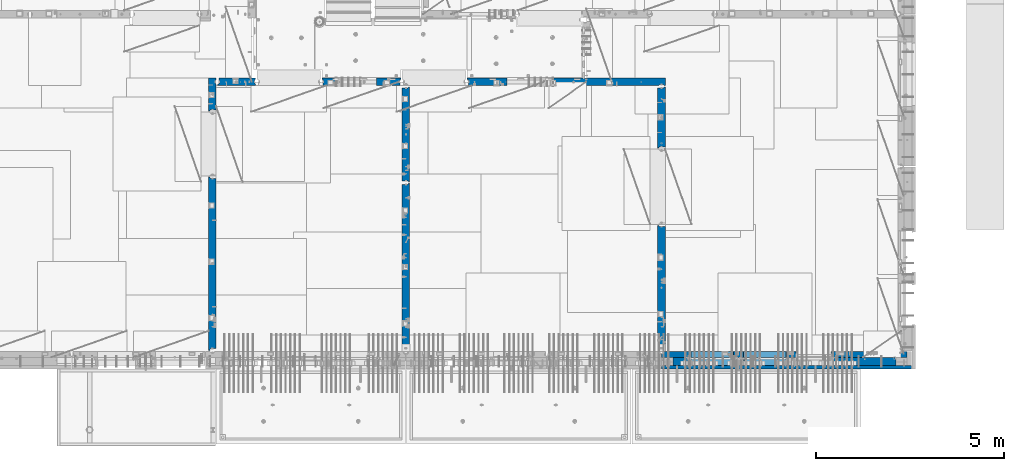
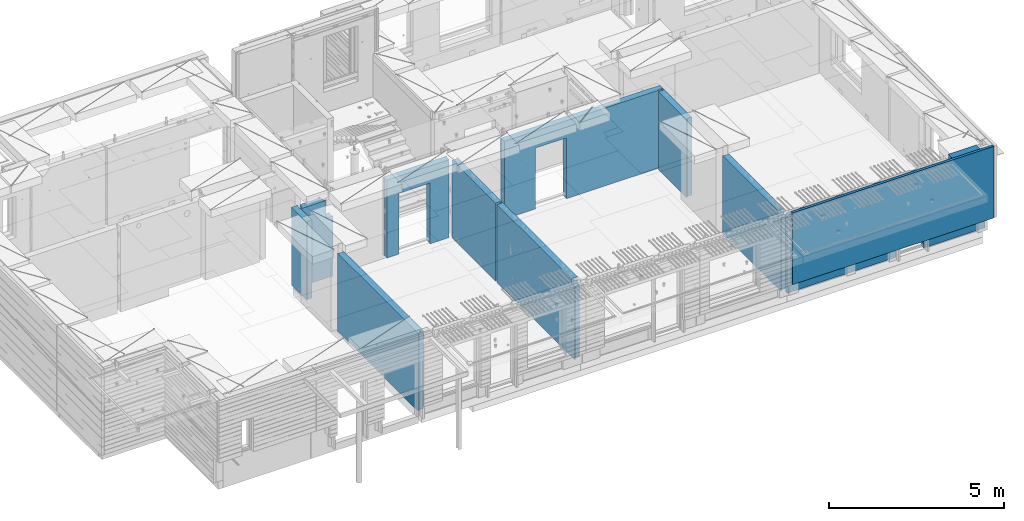
# One storey, part 213 of 325: 12 walls, 10 elements without a shape of their own.
"""IFC2X3 building model written with IfcOpenShell, lengths in millimetres."""

import ifcopenshell
import ifcopenshell.guid

model = None  # the IFC model being written
_history = None  # IfcOwnerHistory: only IFC2X3 demands one
_inside = {}  # id of a spatial element -> (the spatial element, [elements in it])
_under = {}  # id of a project, library or spatial element -> (it, [spatial elements below it])
_declared = {}  # id of a project -> (the project, [libraries it declares])
_typed = {}  # id of a type object -> (the type object, [elements of that type])
_made_of = {}  # id of a material, layer set ... -> (it, [elements and type objects made of it])


def new_model(schema):
    """Start an empty IFC model of exactly this schema.

    Asked for "IFC4X3", IfcOpenShell would pick the latest addendum, in which some entities
    have other attributes; the version numbers below select the first issue.
    IFC2X3 requires an IfcOwnerHistory on every rooted entity: one is made here for all.
    """
    global model, _history
    if schema == "IFC4X3":
        model = ifcopenshell.file(schema_version=(4, 3, 0, 0))
    else:
        model = ifcopenshell.file(schema=schema)
    _inside.clear()
    _under.clear()
    _declared.clear()
    _typed.clear()
    _made_of.clear()
    _history = None
    if model.schema == "IFC2X3":
        org = make("IfcOrganization", Name="unknown")
        user = make(
            "IfcPersonAndOrganization",
            ThePerson=make("IfcPerson", FamilyName="unknown"),
            TheOrganization=org,
        )
        app = make(
            "IfcApplication",
            ApplicationDeveloper=org,
            Version="unknown",
            ApplicationFullName="unknown",
            ApplicationIdentifier="unknown",
        )
        _history = make(
            "IfcOwnerHistory",
            OwningUser=user,
            OwningApplication=app,
            ChangeAction="ADDED",
            CreationDate=0,
        )
    return model


def make(cls, **values):
    """One entity of the class cls with the attributes given. An attribute that is None is left unset."""
    return model.create_entity(
        cls, **{name: value for name, value in values.items() if value is not None}
    )


def rooted(cls, **values):
    """An entity with a GlobalId (a new one), such as an element, a storey or a relation."""
    return make(cls, GlobalId=ifcopenshell.guid.new(), OwnerHistory=_history, **values)


def si_unit(unit_type, name, prefix=None):
    """IfcSIUnit, for example si_unit("LENGTHUNIT", "METRE", prefix="MILLI")."""
    return make("IfcSIUnit", UnitType=unit_type, Prefix=prefix, Name=name)


def assignment(units):
    """IfcUnitAssignment: the units of a project."""
    return None if units is None else make("IfcUnitAssignment", Units=units)


def point(xyz):
    """IfcCartesianPoint."""
    return None if xyz is None else make("IfcCartesianPoint", Coordinates=xyz)


def direction(xyz):
    """IfcDirection."""
    return None if xyz is None else make("IfcDirection", DirectionRatios=xyz)


def frame(location, z_axis=None, x_axis=None):
    """IfcAxis2Placement3D, a coordinate frame: its origin and axes. An axis left out is left unset."""
    return make(
        "IfcAxis2Placement3D",
        Location=point(location),
        Axis=direction(z_axis),
        RefDirection=direction(x_axis),
    )


def origin_with_axes():
    """The frame at (0, 0, 0) with the z axis (0, 0, 1) and the x axis (1, 0, 0) written out."""
    return frame((0.0, 0.0, 0.0), z_axis=(0.0, 0.0, 1.0), x_axis=(1.0, 0.0, 0.0))


def place(relative_to, where):
    """IfcLocalPlacement: puts the frame where relative to a parent placement (None: the world)."""
    return make(
        "IfcLocalPlacement", PlacementRelTo=relative_to, RelativePlacement=where
    )


def context(
    kind, dimensions, precision=None, world=None, true_north=None, identifier=None
):
    """IfcGeometricRepresentationContext, for example the 3D "Model" context."""
    return make(
        "IfcGeometricRepresentationContext",
        ContextIdentifier=identifier,
        ContextType=kind,
        CoordinateSpaceDimension=dimensions,
        Precision=precision,
        WorldCoordinateSystem=world,
        TrueNorth=true_north,
    )


def subcontext(parent, identifier, kind, view, scale=None):
    """IfcGeometricRepresentationSubContext, for example "Body" below "Model"."""
    return make(
        "IfcGeometricRepresentationSubContext",
        ContextIdentifier=identifier,
        ContextType=kind,
        ParentContext=parent,
        TargetScale=scale,
        TargetView=view,
    )


def project(units=None, contexts=None):
    """IfcProject with its units and contexts."""
    return rooted(
        "IfcProject",
        Name="project",
        RepresentationContexts=contexts,
        UnitsInContext=assignment(units),
    )


def spatial(cls, under=None, at=None, **own):
    """A site, building, storey or space (cls), placed at a placement, below another one or the project."""
    s = rooted(cls, ObjectPlacement=at, **own)
    if under is not None:
        _under.setdefault(under.id(), (under, []))[1].append(s)
    return s


def faces_of(points, faces, orient=None, outer=None):
    """IfcFace entities. A face is a list of loops; a loop is a list of indices into points, from 0.

    orient and outer hold one flag for each loop. By default every Orientation is true, the
    first loop of a face is its IfcFaceOuterBound and the others are IfcFaceBound.
    """
    made = []
    for i, loops in enumerate(faces):
        bounds = []
        for j, loop in enumerate(loops):
            is_outer = j == 0 if outer is None else outer[i][j]
            bounds.append(
                make(
                    "IfcFaceOuterBound" if is_outer else "IfcFaceBound",
                    Bound=make("IfcPolyLoop", Polygon=[points[k] for k in loop]),
                    Orientation=True if orient is None else orient[i][j],
                )
            )
        made.append(make("IfcFace", Bounds=bounds))
    return made


def faceted_brep(points, faces, orient=None, outer=None, voids=None):
    """IfcFacetedBrep: a solid bounded by flat faces; with voids (closed shells), ...WithVoids."""
    shared = [point(p) for p in points]
    hull = make("IfcClosedShell", CfsFaces=faces_of(shared, faces, orient, outer))
    if voids is None:
        return make("IfcFacetedBrep", Outer=hull)
    return make(
        "IfcFacetedBrepWithVoids",
        Outer=hull,
        Voids=[
            make(cls, CfsFaces=faces_of(shared, fs, o, b)) for cls, fs, o, b in voids
        ],
    )


def shape(context_of_items, identifier, shape_type, items):
    """IfcShapeRepresentation: the items that make up one representation, for example the "Body"."""
    return make(
        "IfcShapeRepresentation",
        ContextOfItems=context_of_items,
        RepresentationIdentifier=identifier,
        RepresentationType=shape_type,
        Items=items,
    )


def material(Name=None, Category=None):
    """IfcMaterial."""
    return make("IfcMaterial", Name=Name, Category=Category)


def made_of(thing, what):
    """Note that an element or type object is made of a material, layer set ...; save() writes the relation."""
    if what is not None:
        _made_of.setdefault(what.id(), (what, []))[1].append(thing)
    return thing


def type_object(cls, material=None, **own):
    """A type object (cls), such as IfcWallType, which elements share."""
    return made_of(rooted(cls, **own), material)


def element(
    cls,
    number,
    at=None,
    inside=None,
    cuts=None,
    type_object=None,
    material=None,
    context=None,
    identifier="Body",
    shape_type=None,
    held_by="IfcProductDefinitionShape",
    body=None,
    shapes=None,
    **own,
):
    """One element of the class cls, such as IfcWall. Its Tag is "e" and its number.

    at: its placement. inside: the storey or other place that contains it. cuts: it is an
    opening in that element (IfcRelVoidsElement). A single representation is given by context,
    identifier, shape_type and body (its items); several are given by shapes. held_by: the class
    of the entity that holds the representations. save() writes the other relations.
    """
    e = rooted(cls, Tag="e%d" % number, ObjectPlacement=at, **own)
    if body is not None:
        shapes = [shape(context, identifier, shape_type, body)]
    if shapes is not None:
        e.Representation = make(held_by, Representations=shapes)
    if inside is not None:
        _inside.setdefault(inside.id(), (inside, []))[1].append(e)
    if cuts is not None:
        rooted(
            "IfcRelVoidsElement", RelatingBuildingElement=cuts, RelatedOpeningElement=e
        )
    if type_object is not None:
        _typed.setdefault(type_object.id(), (type_object, []))[1].append(e)
    return made_of(e, material)


def aggregate(whole, parts):
    """IfcRelAggregates: a whole, such as a stair, and the parts it consists of."""
    return rooted("IfcRelAggregates", RelatingObject=whole, RelatedObjects=parts)


def save(model, path):
    """Write the relations noted so far, then the file.

    IfcRelAggregates (storeys below a building ...), IfcRelContainedInSpatialStructure (elements
    in a storey), IfcRelDefinesByType, IfcRelAssociatesMaterial and IfcRelDeclares: one each for
    every whole, place, type object, material and project.
    """
    for whole, parts in _under.values():
        aggregate(whole, parts)
    for where, things in _inside.values():
        rooted(
            "IfcRelContainedInSpatialStructure",
            RelatedElements=things,
            RelatingStructure=where,
        )
    for kind, things in _typed.values():
        rooted("IfcRelDefinesByType", RelatedObjects=things, RelatingType=kind)
    for what, things in _made_of.values():
        rooted("IfcRelAssociatesMaterial", RelatedObjects=things, RelatingMaterial=what)
    for by, libraries in _declared.values():
        rooted("IfcRelDeclares", RelatingContext=by, RelatedDefinitions=libraries)
    model.write(path)


model = new_model("IFC2X3")

# Units and contexts
model_context = context("Model", 3, precision=1e-05, world=origin_with_axes())
body_context = subcontext(model_context, "Body", "Model", "MODEL_VIEW")
ifc_project = project(units=[si_unit("LENGTHUNIT", "METRE", prefix="MILLI"), si_unit("AREAUNIT", "SQUARE_METRE"), si_unit("VOLUMEUNIT", "CUBIC_METRE"), si_unit("MASSUNIT", "GRAM", prefix="KILO"), si_unit("TIMEUNIT", "SECOND"), si_unit("PLANEANGLEUNIT", "RADIAN"), si_unit("SOLIDANGLEUNIT", "STERADIAN"), si_unit("THERMODYNAMICTEMPERATUREUNIT", "DEGREE_CELSIUS"), si_unit("LUMINOUSINTENSITYUNIT", "LUMEN")], contexts=[model_context])

# Site, building, storey
site_placement = place(None, origin_with_axes())
site = spatial("IfcSite", under=ifc_project, at=site_placement, CompositionType="ELEMENT")
building_placement = place(site_placement, origin_with_axes())
building = spatial("IfcBuilding", under=site, at=building_placement, CompositionType="ELEMENT")
storey_placement = place(building_placement, origin_with_axes())
storey = spatial("IfcBuildingStorey", under=building, at=storey_placement, Name="1", CompositionType="ELEMENT", Elevation=0.0)

# Assembly, wall
assembly_1_placement = place(storey_placement, origin_with_axes())
assembly_1 = element("IfcElementAssembly", 1, at=assembly_1_placement, inside=storey, AssemblyPlace="NOTDEFINED", PredefinedType="REINFORCEMENT_UNIT")
ifc_material_1 = material(Name="CONCRETE/C25/30")
wall_type_1 = type_object("IfcWallType", PredefinedType="NOTDEFINED")
wall_1_placement = place(assembly_1_placement, frame((16790.0, 15180.0, 83112.5), z_axis=(0.0, 0.0, 1.0), x_axis=(1.0, 0.0, 0.0)))
wall_1 = element("IfcWall", 2, at=wall_1_placement, type_object=wall_type_1, material=ifc_material_1, context=body_context, shape_type="Brep", body=[
    faceted_brep([(1020.0, -65.0002298127583, 737.5), (1020.0, -65.0002298127583, -1357.5), (999.999148194889, -52.0002257561027, -1357.5), (999.999148194889, -52.0002257561027, 737.5), (999.999146609105, 52.0000004570338, -1357.5), (999.999146609105, 52.0000004570338, 737.5), (1019.99914550781, 64.9999999999982, 737.5), (1020.0, 64.9999999999982, -1357.5), (740.0, 100.0, 1357.5), (740.0, -57.0, 1357.5), (740.0, -57.0, 737.5), (740.0, 100.0, 737.5), (50.0, 100.0, 1357.5), (50.0, -48.3299999999999, 1357.5), (0.0, -69.996666666666, 1357.5), (0.0, -100.0, 1357.5), (790.0, -100.0, 1357.5), (790.0, -70.0, 1357.5), (50.0, 100.0, -1357.5), (50.0, -48.3299999999999, -1357.5), (0.0, -69.996666666666, -1357.5), (0.0, -100.0, -1357.5), (1020.0, -100.0, -1357.5), (1020.0, -100.0, 737.5), (790.0, -100.0, 737.5), (790.0, -70.0, 737.5), (790.0, 100.0, 737.5), (840.0, -83.0, 737.5), (840.0, 100.0, 737.5), (1020.0, 100.0, -1357.5), (1020.0, 100.0, 737.5)], [[[0, 1, 2, 3]], [[3, 2, 4, 5]], [[6, 5, 4, 7]], [[8, 9, 10, 11]], [[9, 8, 12, 13, 14, 15, 16, 17]], [[12, 18, 19, 13]], [[13, 19, 20, 14]], [[21, 15, 14, 20]], [[16, 15, 21, 22, 23, 24]], [[17, 16, 24, 25]], [[10, 9, 17, 25]], [[26, 11, 10, 25, 27, 28]], [[29, 18, 12, 8, 11, 26, 28, 30]], [[29, 30, 6, 7]], [[2, 1, 22, 21, 20, 19, 18, 29, 7, 4]], [[23, 22, 1, 0]], [[30, 28, 27, 25, 24, 23, 0, 3, 5, 6]]]),
])
aggregate(assembly_1, [wall_1])

assembly_2_placement = place(storey_placement, origin_with_axes())
assembly_2 = element("IfcElementAssembly", 3, at=assembly_2_placement, inside=storey, AssemblyPlace="NOTDEFINED", PredefinedType="REINFORCEMENT_UNIT")
wall_2_placement = place(assembly_2_placement, frame((28610.0, 13387.9996249472, 83112.5), z_axis=(0.0, 0.0, 1.0), x_axis=(0.0, 1.0, 0.0)))
wall_2 = element("IfcWall", 4, at=wall_2_placement, type_object=wall_type_1, material=ifc_material_1, context=body_context, shape_type="Brep", body=[
    faceted_brep([(30.9999999999982, 70.0000000000073, 1357.5), (30.9999999999982, 70.0000000000073, -1357.5), (60.9999999999982, 57.0000000000036, -1357.5), (60.9999999999982, 57.0000000000036, 1357.5), (60.9999999999982, -100.0, 1357.5), (60.9999999999982, -100.0, -1357.5), (30.9999999999982, 100.0, -1357.5), (30.9999999999982, 100.0, 1357.5), (1631.00037505278, 100.0, 1357.5), (1631.00037505278, 100.0, -1357.5), (1631.00037505278, -56.9999999999964, 1357.5), (1631.00037505278, -56.9999999999964, -1357.5), (1661.00037505278, -70.0, 1357.5), (1661.00037505278, -70.0, -1357.5), (1661.00037505278, -100.0, 1357.5), (1661.00037505278, -100.0, -1357.5)], [[[0, 1, 2, 3]], [[4, 3, 2, 5]], [[6, 7, 8, 9]], [[10, 11, 9, 8]], [[12, 13, 11, 10]], [[14, 15, 13, 12]], [[15, 14, 4, 5]], [[1, 6, 9, 11, 13, 15, 5, 2]], [[7, 6, 1, 0]], [[14, 12, 10, 8, 7, 0, 3, 4]]]),
])
aggregate(assembly_2, [wall_2])

assembly_3_placement = place(storey_placement, origin_with_axes())
assembly_3 = element("IfcElementAssembly", 5, at=assembly_3_placement, inside=storey, AssemblyPlace="NOTDEFINED", PredefinedType="REINFORCEMENT_UNIT")
wall_3_placement = place(assembly_3_placement, frame((28610.0, 8000.0, 83112.5), z_axis=(0.0, 0.0, 1.0), x_axis=(0.0, 1.0, 0.0)))
wall_3 = element("IfcWall", 6, at=wall_3_placement, type_object=wall_type_1, material=ifc_material_1, context=body_context, shape_type="Brep", body=[
    faceted_brep([(200.000052014346, -100.0, 1157.50076293945), (200.000052014346, 100.0, 1157.50076293945), (30.0, 100.0, 1157.50076293945), (30.0, 70.0, 1157.50076293945), (80.0, 57.0, 1157.50076293945), (80.0, -100.0, 1157.50076293945), (200.000052014346, -100.0, 1357.50076293945), (200.000052014346, 100.0, 1357.5), (30.0, 70.0, -1357.5), (30.0, 100.0, -1357.5), (3360.0, 100.0, -1357.5), (3360.0, 70.0000000000073, -1357.5), (3330.0, 57.0000000000036, -1357.5), (3330.0, -100.0, -1357.5), (80.0, -100.0, -1357.5), (80.0, 57.0, -1357.5), (3360.0, 100.0, 1357.5), (3360.0, 70.0000000000073, 1357.5), (3330.0, 57.0000000000036, 1357.5), (3330.0, -100.0, 1357.5)], [[[0, 1, 2, 3, 4, 5]], [[6, 7, 1, 0]], [[8, 9, 10, 11, 12, 13, 14, 15]], [[10, 16, 17, 11]], [[18, 12, 11, 17]], [[19, 13, 12, 18]], [[5, 14, 13, 19, 6, 0]], [[15, 14, 5, 4]], [[8, 15, 4, 3]], [[9, 8, 3, 2]], [[16, 10, 9, 2, 1, 7]], [[19, 18, 17, 16, 7, 6]]]),
])
aggregate(assembly_3, [wall_3])

assembly_4_placement = place(storey_placement, origin_with_axes())
assembly_4 = element("IfcElementAssembly", 7, at=assembly_4_placement, inside=storey, AssemblyPlace="NOTDEFINED", PredefinedType="REINFORCEMENT_UNIT")
wall_4_placement = place(assembly_4_placement, frame((23410.0002919986, 15180.0, 83112.5), z_axis=(0.0, 0.0, 1.0), x_axis=(1.0, 0.0, 0.0)))
wall_4 = element("IfcWall", 8, at=wall_4_placement, type_object=wall_type_1, material=ifc_material_1, context=body_context, shape_type="Brep", body=[
    faceted_brep([(3134.99885559082, 100.0, 762.5), (3147.99885559082, 80.0, 762.5), (3251.99885559082, 80.0, 762.5), (3264.99885559082, 100.0, 762.5), (3147.99885559082, 80.0, 1357.5), (3134.99885559082, 100.0, 1357.5), (3251.99885559082, 80.0, 1357.5), (3264.99885559082, 100.0, 1357.5), (5299.99970800144, -100.0, -1357.5), (5299.99970800144, -100.0, 1357.5), (5264.99970800144, -100.0, 1357.5), (5264.99970800144, -100.0, -1357.5), (5251.99970800144, -70.0, 1357.5), (5251.99970800144, -70.0, -1357.5), (5147.99970800144, -70.0, 1357.5), (5147.99970800144, -70.0, -1357.5), (5134.99970800144, -100.0, 1357.5), (5134.99970800144, -100.0, -1357.5), (59.9988535092562, -100.0, 1357.5), (59.9988535092562, -100.0, -1357.5), (1090.00039464695, -100.0, -1357.5), (1090.00039464695, -100.0, 762.5), (2110.00039464695, -100.0, 762.5), (2110.00039464695, -100.0, -1357.5), (59.9988535092562, 57.0, 1357.5), (59.9988535092562, 57.0, -1357.5), (29.9988535092562, 70.0000000000018, 1357.5), (29.9988535092562, 70.0000000000018, -1357.5), (29.9988535092562, 100.0, 1357.5), (29.9988535092562, 100.0, -1357.5), (1090.00039464695, 100.0, -1357.5), (1090.00039464695, 100.0, 762.5), (2110.00039464695, 100.0, 762.5), (2110.00039464695, 100.0, -1357.5), (5299.99970800144, 100.0, -1357.5), (5299.99970800144, 100.0, 1357.5)], [[[0, 1, 2, 3]], [[4, 1, 0, 5]], [[6, 2, 1, 4]], [[7, 3, 2, 6]], [[8, 9, 10, 11]], [[10, 12, 13, 11]], [[14, 15, 13, 12]], [[16, 17, 15, 14]], [[17, 16, 18, 19, 20, 21, 22, 23]], [[24, 25, 19, 18]], [[26, 27, 25, 24]], [[28, 29, 27, 26]], [[19, 25, 27, 29, 30, 20]], [[31, 21, 20, 30]], [[32, 22, 21, 31]], [[33, 23, 22, 32]], [[34, 8, 11, 13, 15, 17, 23, 33]], [[9, 8, 34, 35]], [[4, 5, 28, 26, 24, 18, 16, 14, 12, 10, 9, 35, 7, 6]], [[35, 34, 33, 32, 31, 30, 29, 28, 5, 0, 3, 7]]]),
])
aggregate(assembly_4, [wall_4])

assembly_5_placement = place(storey_placement, origin_with_axes())
assembly_5 = element("IfcElementAssembly", 9, at=assembly_5_placement, inside=storey, AssemblyPlace="NOTDEFINED", PredefinedType="REINFORCEMENT_UNIT")
wall_5_placement = place(assembly_5_placement, frame((21810.0, 12500.0, 83112.5), z_axis=(0.0, 0.0, 1.0), x_axis=(0.0, 1.0, 0.0)))
wall_5 = element("IfcWall", 10, at=wall_5_placement, type_object=wall_type_1, material=ifc_material_1, context=body_context, shape_type="Brep", body=[
    faceted_brep([(2519.9998239177, -57.0, 1357.5), (2519.9998239177, -57.0, -1357.5), (2519.9998239177, 100.0, -1357.5), (2519.9998239177, 100.0, 1357.5), (2549.9998239177, -70.0, 1357.5), (2549.9998239177, -70.0, -1357.5), (45.0, 100.0, 1357.5), (45.0, 100.0, -1357.5), (45.0, -57.0, -1357.5), (45.0, -57.0, 1357.5), (15.0, -70.0, 1357.5), (15.0, -70.0000000000036, -1357.5), (15.0, -100.0, -1357.5), (15.0, -100.0, 1357.5), (2549.9998239177, -100.0, -1357.5), (2549.9998239177, -100.0, 1357.5)], [[[0, 1, 2, 3]], [[4, 5, 1, 0]], [[6, 7, 8, 9]], [[10, 9, 8, 11]], [[12, 13, 10, 11]], [[13, 12, 14, 15]], [[3, 6, 9, 10, 13, 15, 4, 0]], [[7, 6, 3, 2]], [[14, 12, 11, 8, 7, 2, 1, 5]], [[15, 14, 5, 4]]]),
])
aggregate(assembly_5, [wall_5])

assembly_6_placement = place(storey_placement, origin_with_axes())
assembly_6 = element("IfcElementAssembly", 11, at=assembly_6_placement, inside=storey, AssemblyPlace="NOTDEFINED", PredefinedType="REINFORCEMENT_UNIT")
wall_6_placement = place(assembly_6_placement, frame((21810.0, 8000.0, 83112.5), z_axis=(0.0, 0.0, 1.0), x_axis=(0.0, 1.0, 0.0)))
wall_6 = element("IfcWall", 12, at=wall_6_placement, type_object=wall_type_1, material=ifc_material_1, context=body_context, shape_type="Brep", body=[
    faceted_brep([(200.000052014346, -100.0, 1157.50076293945), (200.000052014346, 100.0, 1157.50076293945), (30.0, 100.0, 1157.50076293945), (30.0, 70.0, 1157.50076293945), (80.0, 57.0, 1157.50076293945), (80.0, -100.0, 1157.50076293945), (200.000052014346, -100.0, 1357.50076293945), (200.000052014346, 100.0, 1357.5), (30.0, 70.0, -1357.5), (30.0, 100.0, -1357.5), (4455.0, 100.0, -1357.5), (4455.0, -57.0, -1357.5), (4485.0, -70.0000000000036, -1357.5), (4485.0, -100.0, -1357.5), (80.0, -100.0, -1357.5), (80.0, 57.0, -1357.5), (4455.0, -57.0, 1357.5), (4455.0, 100.0, 1357.5), (4485.0, -70.0000000000036, 1357.5), (4485.0, -100.0, 1357.5)], [[[0, 1, 2, 3, 4, 5]], [[6, 7, 1, 0]], [[8, 9, 10, 11, 12, 13, 14, 15]], [[16, 11, 10, 17]], [[18, 12, 11, 16]], [[19, 13, 12, 18]], [[5, 14, 13, 19, 6, 0]], [[15, 14, 5, 4]], [[8, 15, 4, 3]], [[9, 8, 3, 2]], [[17, 10, 9, 2, 1, 7]], [[19, 18, 16, 17, 7, 6]]]),
])
aggregate(assembly_6, [wall_6])

assembly_7_placement = place(storey_placement, origin_with_axes())
assembly_7 = element("IfcElementAssembly", 13, at=assembly_7_placement, inside=storey, AssemblyPlace="NOTDEFINED", PredefinedType="REINFORCEMENT_UNIT")
wall_7_placement = place(assembly_7_placement, frame((19569.9991455076, 15180.0000000001, 83112.5), z_axis=(0.0, 0.0, 1.0), x_axis=(1.0, 0.0, 0.0)))
wall_7 = element("IfcWall", 14, at=wall_7_placement, type_object=wall_type_1, material=ifc_material_1, context=body_context, shape_type="Brep", body=[
    faceted_brep([(30.0000000001819, 56.9999999999745, 1357.5), (30.0000000001819, 56.9999999999745, -1357.5), (30.0000000001819, -100.0, -1357.5), (30.0000000001819, -100.0, 1357.5), (0.0, 69.9999999999745, 1357.5), (0.0, 69.9999999999745, -1357.5), (1450.00154113788, 100.0, -1357.5), (1450.00154113788, -100.0, -1357.5), (1450.00154113788, -100.0, 762.5), (1450.00154113788, 100.0, 762.5), (430.001541137881, 100.0, 762.5), (430.001541137881, -100.0, 762.5), (430.001541137881, -100.0, -1357.5), (430.001541137881, 100.0, -1357.5), (0.0, 100.0, -1357.5), (0.0, 100.0, 1357.5), (2110.00085449221, 100.0, 1357.5), (2110.00085449221, 100.0, -1357.5), (2110.00085449272, 70.0000000037435, 1357.5), (2110.00085449221, 70.0000000037435, -1357.5), (2080.00085191853, -100.0, -1357.5), (2080.00085558004, 57.0000004585763, -1357.5), (2080.00085558004, 57.0000004585763, 1357.5), (2080.00085191853, -100.0, 1357.5)], [[[0, 1, 2, 3]], [[4, 5, 1, 0]], [[6, 7, 8, 9]], [[10, 11, 12, 13]], [[9, 8, 11, 10]], [[13, 14, 15, 16, 17, 6, 9, 10]], [[17, 16, 18, 19]], [[20, 7, 6, 17, 19, 21]], [[18, 22, 21, 19]], [[23, 20, 21, 22]], [[12, 11, 8, 7, 20, 23, 3, 2]], [[14, 13, 12, 2, 1, 5]], [[15, 14, 5, 4]], [[23, 22, 18, 16, 15, 4, 0, 3]]]),
])
aggregate(assembly_7, [wall_7])

assembly_8_placement = place(storey_placement, origin_with_axes())
assembly_8 = element("IfcElementAssembly", 15, at=assembly_8_placement, inside=storey, AssemblyPlace="NOTDEFINED", PredefinedType="REINFORCEMENT_UNIT")
wall_8_placement = place(assembly_8_placement, frame((16660.0, 8000.0, 83112.5), z_axis=(0.0, 0.0, 1.0), x_axis=(0.0, 1.0, 0.0)))
wall_8 = element("IfcWall", 16, at=wall_8_placement, type_object=wall_type_1, material=ifc_material_1, context=body_context, shape_type="Brep", body=[
    faceted_brep([(30.0000000000009, 70.0, 1357.5), (30.0, 70.0, -1357.5), (80.0, 57.0, -1357.5), (79.99999955967, 57.0000001052285, 1357.5), (79.9999996695051, -100.0, 1357.5), (80.0, -100.0, -1357.5), (30.0, 100.0, -1357.5), (30.0000000000009, 100.0, 1357.5), (4644.99239711402, 100.0, 1357.5), (4644.99239711402, 100.0, -1357.5), (4644.99653549905, 70.0145277302508, 1357.5), (4644.99653549905, 70.0145277302508, -1357.5), (4614.97833252975, 57.001718635147, 1357.5), (4614.97833252975, 57.001718635147, -1357.5), (4615.00000080787, -100.0, 1357.5), (4615.00000080787, -100.0, -1357.5)], [[[0, 1, 2, 3]], [[4, 3, 2, 5]], [[6, 7, 8, 9]], [[9, 8, 10, 11]], [[12, 13, 11, 10]], [[14, 15, 13, 12]], [[15, 14, 4, 5]], [[1, 6, 9, 11, 13, 15, 5, 2]], [[7, 6, 1, 0]], [[14, 12, 10, 8, 7, 0, 3, 4]]]),
])
aggregate(assembly_8, [wall_8])

assembly_9_placement = place(storey_placement, origin_with_axes())
assembly_9 = element("IfcElementAssembly", 17, at=assembly_9_placement, inside=storey, AssemblyPlace="NOTDEFINED", PredefinedType="REINFORCEMENT_UNIT")
wall_9_placement = place(assembly_9_placement, frame((16660.0, 14375.0001284873, 83112.5), z_axis=(0.0, 0.0, 1.0), x_axis=(0.0, 1.0, 0.0)))
wall_9 = element("IfcWall", 18, at=wall_9_placement, type_object=wall_type_1, material=ifc_material_1, context=body_context, shape_type="Brep", body=[
    faceted_brep([(29.9765698802239, 70.004139724977, 1357.5), (29.9765698802239, 70.004139724977, -1357.5), (59.9783637637502, 57.008280238686, -1357.50000000001), (59.9783637637502, 57.008280238686, 1357.5), (60.0000329474624, -100.0, 1357.5), (60.0000329474624, -100.0, -1357.5), (29.972430061518, 100.0, -1357.5), (29.972430061518, 100.0, 1357.5), (904.999871512742, 100.0, 1357.5), (904.999871512742, 100.0, -1357.5), (904.999871512742, -100.0, 1357.5), (904.999871512742, -100.0, -1357.5), (869.99987151274, -100.0, 1357.5), (869.99987151274, -100.0, -1357.5), (856.999871512742, -80.0, 1357.5), (856.999871512742, -80.0, -1357.5), (752.999871512742, -80.0, 1357.5), (752.999871512742, -80.0, -1357.5), (739.999871512746, -100.0, 1357.5), (739.999871512746, -100.0, -1357.5)], [[[0, 1, 2, 3]], [[4, 3, 2, 5]], [[6, 7, 8, 9]], [[10, 11, 9, 8]], [[11, 10, 12, 13]], [[12, 14, 15, 13]], [[16, 17, 15, 14]], [[18, 19, 17, 16]], [[19, 18, 4, 5]], [[1, 6, 9, 11, 13, 15, 17, 19, 5, 2]], [[7, 6, 1, 0]], [[18, 16, 14, 12, 10, 8, 7, 0, 3, 4]]]),
])
aggregate(assembly_9, [wall_9])

# Assembly, walls
assembly_10_placement = place(storey_placement, origin_with_axes())
assembly_10 = element("IfcElementAssembly", 19, at=assembly_10_placement, inside=storey, AssemblyPlace="NOTDEFINED", PredefinedType="REINFORCEMENT_UNIT")
ifc_material_2 = material(Name="COS5gt")
wall_type_2 = type_object("IfcWallType", PredefinedType="NOTDEFINED")
wall_10_placement = place(assembly_10_placement, frame((34845.0, 7740.0, 83247.5), z_axis=(0.0, 0.0, 1.0), x_axis=(-1.0, 3.00000001838171e-08, 0.0)))
wall_10 = element("IfcWall", 20, at=wall_10_placement, type_object=wall_type_2, material=ifc_material_2, context=body_context, shape_type="Brep", body=[
    faceted_brep([(0.0, 90.0, -957.5), (1680.00110766775, 90.0, -957.5), (1680.00110766775, 90.0, -1007.5), (0.0, 90.0, -1007.5), (0.0, 110.0, -957.5), (1680.00110766775, 110.0, -957.5), (1680.00110766775, -110.0, 857.5), (1680.00110766775, 110.0, 857.5), (2649.99996185248, 110.0, 857.5), (2649.99996185248, -10.0, 857.5), (2649.99996185248, -110.0, 857.5), (0.0, 110.0, 1492.5), (0.0, -110.0, 1492.5), (917.0, -110.0, 1492.5), (917.0, 110.0, 1492.5), (917.0, 110.0, 1202.5), (0.0, 110.0, 1202.50000000001), (917.0, 90.0, 1202.5), (0.0, 90.0, 1202.5), (917.0, -110.0, 1202.5), (2649.99996185248, -110.0, 1202.5), (2649.99996185248, -10.0, 1202.5), (2649.99996185248, 90.0, 1202.5), (0.0, 90.0, 1152.5), (2649.99996185248, 90.0, 1152.5), (2649.99996185248, 110.0, 1152.5), (0.0, 110.0, 1152.5), (0.0, -110.0, -1007.5), (1680.00110766775, -110.0, -1007.5), (2920.0018706072, 90.0, -957.5), (4049.99996185248, 90.0, -957.5), (4049.99996185248, 90.0, -1007.5), (2920.0018706072, 90.0, -1007.5), (2920.0018706072, 110.0, -957.5), (4049.99996185248, 110.0, -957.5), (2920.0018706072, 90.0, 1152.5), (4049.99996185248, 90.0, 1152.5), (4049.99996185248, 110.0, 1152.5), (2920.0018706072, 110.0, 1152.5), (2920.0018706072, 90.0, 1202.5), (4049.99996185248, 90.0, 1202.5), (2920.0018706072, -10.0, 1202.5), (2920.0018706072, -110.0, 1202.5), (4049.99996185248, -110.0, 1202.5), (4049.99996185248, -10.0, 1202.5), (2920.0018706072, -10.0, -1007.5), (2920.0018706072, -110.0, -1007.5), (4049.99996185248, -10.0, -1007.5), (4049.99996185248, -110.0, -1007.5), (4045.94781655315, -110.0, -813.445945945947), (4040.0018706072, 110.0, -807.5), (4010.0018706072, 110.0, -807.5), (2960.0018706072, 110.0, -807.5), (2930.0018706072, 110.0, -807.5), (2924.05592466125, -110.0, -813.445945945947), (2924.05592466125, -110.0, 813.445945945947), (4045.94781655315, -110.0, 813.445945945947), (4040.0018706072, 110.0, -802.5), (4040.0018706072, 110.0, 807.5), (2930.0018706072, 110.0, 807.5), (2930.0018706072, 110.0, -802.5), (4320.0018706072, 90.0, -957.5), (5929.99996185248, 90.0, -957.5), (5930.0, 90.0, -1007.5), (4320.0018706072, 90.0, -1007.5), (4320.0018706072, 110.0, -957.5), (5930.0, 110.0, -957.5), (4320.0018706072, 90.0, 1152.5), (5929.99996185248, 90.0, 1152.5), (5930.0, 110.0, 1152.5), (4320.0018706072, 110.0, 1152.5), (4320.0018706072, 90.0, 1202.5), (5930.0, 90.0, 1202.5), (4320.0018706072, -10.0, 1202.5), (4320.0018706072, -110.0, 1202.5), (5930.0, -110.0, 1202.5), (5930.0, -10.0, 1202.5), (5930.0, -110.0, -1007.5), (5930.0, -10.0, -1007.5), (4320.0018706072, -110.0, -1007.5), (4320.0018706072, -10.0, -1007.5), (5445.94552773479, -110.0, -813.445945945947), (5439.99958178884, 110.0, -807.5), (5409.99958178884, 110.0, -807.5), (4359.99958178884, 110.0, -807.5), (4329.99958178884, 110.0, -807.5), (4324.05363584289, -110.0, -813.445945945947), (4324.05363584289, -110.0, 813.445945945947), (5445.94552773479, -110.0, 813.445945945947), (5439.99958178884, 110.0, -802.5), (5439.99958178884, 110.0, 807.5), (4329.99958178884, 110.0, 807.5), (4329.99958178884, 110.0, -802.5)], [[[0, 1, 2, 3]], [[4, 5, 1, 0]], [[6, 7, 8, 9, 10]], [[11, 12, 13, 14]], [[11, 14, 15, 16]], [[16, 15, 17, 18]], [[14, 13, 19, 17, 15]], [[19, 20, 21, 22, 17]], [[23, 24, 25, 26]], [[18, 17, 22, 24, 23]], [[21, 9, 8, 25, 24, 22]], [[20, 10, 9, 21]], [[19, 13, 12, 27, 28, 6, 10, 20]], [[28, 27, 3, 2]], [[7, 6, 28, 2, 1, 5]], [[26, 25, 8, 7, 5, 4]], [[27, 12, 11, 16, 18, 23, 26, 4, 0, 3]], [[29, 30, 31, 32]], [[33, 34, 30, 29]], [[35, 36, 37, 38]], [[39, 40, 36, 35]], [[41, 42, 43, 44, 40, 39]], [[42, 41, 45, 46]], [[47, 48, 46, 45, 32, 31]], [[37, 36, 40, 44, 47, 31, 30, 34]], [[43, 48, 47, 44]], [[49, 50, 51, 52, 53, 54]], [[42, 46, 48, 43], [49, 54, 55, 56]], [[57, 50, 49, 56, 58]], [[55, 59, 58, 56]], [[54, 53, 60, 59, 55]], [[38, 37, 34, 33], [53, 52, 51, 50, 57, 58, 59, 60]], [[45, 41, 39, 35, 38, 33, 29, 32]], [[61, 62, 63, 64]], [[65, 66, 62, 61]], [[67, 68, 69, 70]], [[71, 72, 68, 67]], [[73, 74, 75, 76, 72, 71]], [[69, 68, 72, 76, 75, 77, 78, 63, 62, 66]], [[78, 77, 79, 80, 64, 63]], [[74, 73, 80, 79]], [[81, 82, 83, 84, 85, 86]], [[77, 75, 74, 79], [81, 86, 87, 88]], [[89, 82, 81, 88, 90]], [[87, 91, 90, 88]], [[86, 85, 92, 91, 87]], [[70, 69, 66, 65], [85, 84, 83, 82, 89, 90, 91, 92]], [[80, 73, 71, 67, 70, 65, 61, 64]]]),
])
ifc_material_3 = material(Name="CONCRETE/C30/37")
wall_type_3 = type_object("IfcWallType", PredefinedType="NOTDEFINED")
wall_11_placement = place(assembly_10_placement, frame((35265.0, 7587.5, 83247.5), z_axis=(0.0, 0.0, 1.0), x_axis=(-1.0, 3.00000001838171e-08, 0.0)))
wall_11 = element("IfcWall", 21, at=wall_11_placement, type_object=wall_type_3, material=ifc_material_3, context=body_context, shape_type="Brep", body=[
    faceted_brep([(0.0, 42.5, 1492.5), (0.0, -42.5, 1492.5), (6650.0, -42.5, 1492.5), (6650.0, 42.5, 1492.5), (0.0, -42.5, -1007.5), (6650.0, -42.5, -1007.5), (6650.0, 42.5, -1007.5), (0.0, 42.5, -1007.5)], [[[0, 1, 2, 3]], [[2, 1, 4, 5]], [[3, 2, 5, 6]], [[0, 3, 6, 7]], [[1, 0, 7, 4]], [[6, 5, 4, 7]]]),
])
ifc_material_4 = material(Name="CONCRETE/C35/45")
wall_type_4 = type_object("IfcWallType", PredefinedType="NOTDEFINED")
wall_12_placement = place(assembly_10_placement, frame((35145.0, 7925.0, 83112.5), z_axis=(0.0, 0.0, 1.0), x_axis=(-1.0, 3.00000001838171e-08, 0.0)))
wall_12 = element("IfcWall", 22, at=wall_12_placement, type_object=wall_type_4, material=ifc_material_4, context=body_context, shape_type="Brep", body=[
    faceted_brep([(202.000000451517, -54.9999973486238, 1357.5), (202.000000451517, -54.9999973486238, -1357.5), (214.999999722531, -75.0, -1357.5), (214.999999722531, -75.0, 1357.5), (128.000000410604, -54.9999993903875, 1357.5), (128.000000410604, -54.9999993903875, -1357.5), (115.0, -75.0, 1357.5), (115.0, -75.0, -1357.5), (0.0, -75.0, -1357.5), (0.0, -75.0, 1357.5), (0.0, 75.0, 1357.5), (0.0, 75.0, -1357.5), (6470.0, -75.0, 1357.5), (6530.0, -15.0, 1357.5), (6530.0, 75.0, 1357.5), (6530.0, 75.0, -1357.5), (6530.0, -15.0, -1357.5), (6470.0, -75.0, -1357.5), (2950.00110766775, -75.0, -1357.5), (2946.15495382159, 75.0, -1357.5), (2950.00110766775, -75.0, 952.5), (2946.1549538216, 75.0, 948.653846153844), (2020.00110766775, -75.0, 952.5), (2023.8472615139, 75.0, 948.653846153844), (2020.00110766775, -75.0, -1357.5), (2023.8472615139, 75.0, -1357.5), (5749.99958178884, -75.0, -682.5), (5745.94552773479, 75.0, -678.445945945947), (4624.05363584289, 75.0, -678.445945945947), (4619.99958178884, -75.0, -682.5), (5749.99958178884, -75.0, 952.5), (5745.94552773479, 75.0, 948.445945945947), (4619.99958178884, -75.0, 952.5), (4624.05363584289, 75.0, 948.445945945947), (4345.94781655315, 75.0, -678.445945945947), (4345.94781655315, 75.0, 948.445945945947), (3224.05592466125, 75.0, 948.445945945947), (3224.05592466125, 75.0, -678.445945945947), (3220.0018706072, -75.0, -682.5), (3220.0018706072, -75.0, 952.5), (4350.0018706072, -75.0, -682.5), (4350.0018706072, -75.0, 952.5)], [[[0, 1, 2, 3]], [[4, 5, 1, 0]], [[6, 7, 5, 4]], [[8, 9, 10, 11]], [[0, 3, 12, 13, 14, 10, 9, 6, 4]], [[15, 14, 13, 16]], [[12, 17, 16, 13]], [[15, 16, 17, 18, 19]], [[19, 18, 20, 21]], [[22, 23, 21, 20]], [[24, 25, 23, 22]], [[26, 27, 28, 29]], [[27, 26, 30, 31]], [[32, 33, 31, 30]], [[29, 28, 33, 32]], [[11, 10, 14, 15, 19, 21, 23, 25], [34, 35, 36, 37], [27, 31, 33, 28]], [[38, 37, 36, 39]], [[40, 34, 37, 38]], [[34, 40, 41, 35]], [[39, 36, 35, 41]], [[24, 22, 20, 18, 17, 12, 3, 2], [40, 38, 39, 41], [26, 29, 32, 30]], [[8, 11, 25, 24, 2, 1, 5, 7]], [[9, 8, 7, 6]]]),
])
aggregate(assembly_10, [wall_10, wall_11, wall_12])

save(model, "model.ifc")
